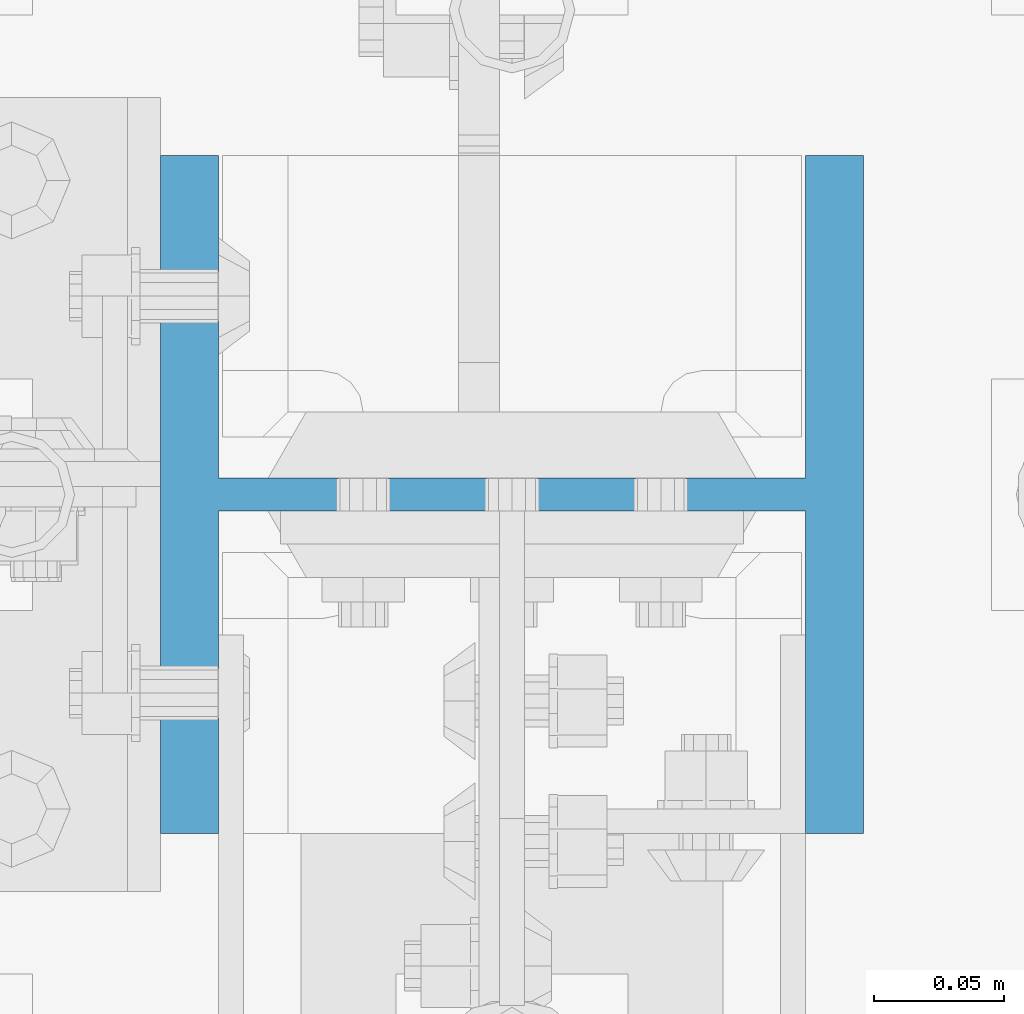
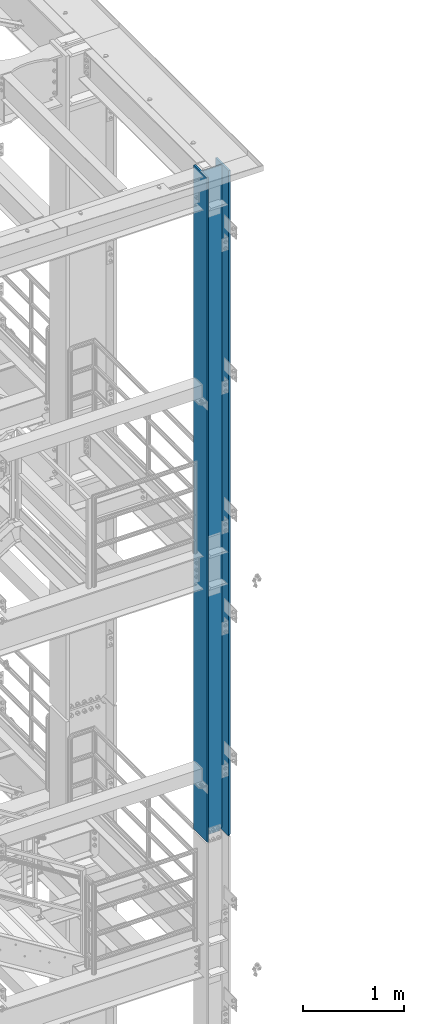
# One storey, part 652 of 1876: 1 column, 1 element without a shape of its own.
"""IFC2X3 building model written with IfcOpenShell, lengths in millimetres."""

from ifc_helpers import new_model, si_unit, frame, origin_with_axes, place, context, subcontext, project, spatial, faceted_brep, material, type_object, element, aggregate, save


model = new_model("IFC2X3")

# Units and contexts
model_context = context("Model", 3, precision=1e-05, world=origin_with_axes())
body_context = subcontext(model_context, "Body", "Model", "MODEL_VIEW")
ifc_project = project(units=[si_unit("LENGTHUNIT", "METRE", prefix="MILLI"), si_unit("AREAUNIT", "SQUARE_METRE"), si_unit("VOLUMEUNIT", "CUBIC_METRE"), si_unit("MASSUNIT", "GRAM", prefix="KILO"), si_unit("TIMEUNIT", "SECOND"), si_unit("PLANEANGLEUNIT", "RADIAN"), si_unit("SOLIDANGLEUNIT", "STERADIAN"), si_unit("THERMODYNAMICTEMPERATUREUNIT", "DEGREE_CELSIUS"), si_unit("LUMINOUSINTENSITYUNIT", "LUMEN")], contexts=[model_context])

# Site, building, storey
site_placement = place(None, origin_with_axes())
site = spatial("IfcSite", under=ifc_project, at=site_placement, CompositionType="ELEMENT")
building_placement = place(site_placement, origin_with_axes())
building = spatial("IfcBuilding", under=site, at=building_placement, Name="Undefined", CompositionType="ELEMENT")
storey_placement = place(building_placement, origin_with_axes())
storey = spatial("IfcBuildingStorey", under=building, at=storey_placement, Name="Undefined", CompositionType="ELEMENT", Elevation=0.0)

# Assembly, column
assembly_placement = place(storey_placement, origin_with_axes())
assembly = element("IfcElementAssembly", 1, at=assembly_placement, inside=storey, Name="COLUMN", AssemblyPlace="NOTDEFINED", PredefinedType="RIGID_FRAME")
ifc_material = material(Name="STEEL/A992")
column_type = type_object("IfcColumnType", Name="W10X77", PredefinedType="NOTDEFINED")
column_placement = place(assembly_placement, frame((7620.0, -7112.0, 14528.8), z_axis=(-1.0, 0.0, 0.0), x_axis=(0.0, 0.0, 1.0)))
column = element("IfcColumn", 2, at=column_placement, type_object=column_type, material=ifc_material, Name="COLUMN", ObjectType="W10X77", context=body_context, shape_type="Brep", body=[
    faceted_brep([(15.8749999999945, 6.35000000000036, 82.471111788822), (15.8749999999945, 6.35000000000036, -82.471111788822), (6.35000000000036, -3.17500029428084, -80.9625), (6.35000000000036, -3.17500029428084, 80.9625), (8026.39999999999, 130.175, -134.9375), (8026.39999999999, -130.175, -134.9375), (25.4000000342548, -130.175, -134.9375), (25.4000000342548, 130.175, -134.9375), (8026.39999999999, -130.175, -112.7125), (38.1000000342628, -130.175, -112.7125), (6.35000000000036, -130.175, -112.7125), (6.35000000000036, -130.175, -115.887499965744), (38.1000000342628, -6.35000000000036, -112.7125), (6.35000000000036, -6.35000000000036, -112.7125), (8026.39999999999, -6.35000000000036, -112.7125), (6.35000000000036, -130.175, 112.7125), (38.1000000342628, -130.175, 112.7125), (8026.39999999999, -130.175, 112.7125), (8026.39999999999, -130.175, 134.9375), (25.4000000342548, -130.175, 134.9375), (6.35000000000036, -130.175, 115.887499965744), (8026.39999999999, 130.175, 134.9375), (25.4000000342548, 130.175, 134.9375), (6.35000000000036, 130.175, 115.887499965744), (8026.39999999999, 130.175, 112.7125), (38.1000000342628, 130.175, 112.7125), (6.35000000000036, 130.175, 112.7125), (6.35000000000036, -6.35000000000036, 112.7125), (6.35000000000036, 6.35000000000036, 112.7125), (6.35000000000036, -3.17500029428084, 112.7125), (38.1000000342628, -6.35000000000036, 112.7125), (8026.39999999999, -6.35000000000036, 112.7125), (36.5460444266337, -6.35000000000036, 102.901210428595), (32.0362896056668, -6.35000000000036, 94.050318239714), (25.0121817945492, -6.35000000000036, 87.0262104285954), (16.1612896056668, -6.35000000000036, 82.5164556076289), (6.35000000000036, -6.35000000000036, 80.9625), (6.35000000000036, -6.35000000000036, -80.9625), (16.1612896056668, -6.35000000000036, -82.5164556076289), (25.0121817945492, -6.35000000000036, -87.0262104285954), (32.0362896056668, -6.35000000000036, -94.050318239714), (36.5460444266337, -6.35000000000036, -102.901210428595), (16.1612896056668, 6.35000000000036, -82.5164556076289), (25.0121817945492, 6.35000000000036, -87.0262104285954), (32.0362896056668, 6.35000000000036, -94.050318239714), (36.5460444266337, 6.35000000000036, -102.901210428595), (38.1000000342628, 6.35000000000036, -112.7125), (38.1000000342628, 130.175, -112.7125), (6.35000000000036, 130.175, -112.7125), (6.35000000000036, 6.35000000000036, -112.7125), (15.8749999999945, 6.35000000000036, -112.7125), (8026.39999999999, 6.35000000000036, -112.7125), (8026.39999999999, 130.175, -112.7125), (6.35000000000036, -3.17500029428084, -112.7125), (6.35000000000036, 130.175, -115.887499965744), (8026.39999999999, 6.35000000000036, 112.7125), (38.1000000342628, 6.35000000000036, 112.7125), (15.8749999999945, 6.35000000000036, 112.7125), (36.5460444266337, 6.35000000000036, 102.901210428595), (32.0362896056668, 6.35000000000036, 94.050318239714), (25.0121817945492, 6.35000000000036, 87.0262104285954), (16.1612896056668, 6.35000000000036, 82.5164556076289)], [[[0, 1, 2, 3]], [[4, 5, 6, 7]], [[5, 8, 9, 10, 11, 6]], [[12, 13, 10, 9, 8, 14]], [[15, 16, 17, 18, 19, 20]], [[18, 21, 22, 19]], [[19, 22, 23, 20]], [[21, 24, 25, 26, 23, 22]], [[27, 15, 20, 23, 26, 28, 29]], [[16, 15, 27, 30, 31, 17]], [[14, 31, 30, 32, 33, 34, 35, 36, 37, 38, 39, 40, 41, 12]], [[38, 42, 43, 39]], [[39, 43, 44, 40]], [[40, 44, 45, 41]], [[41, 45, 46, 12]], [[47, 48, 49, 50, 46, 51, 52]], [[12, 46, 50, 49, 53, 13]], [[49, 48, 54, 11, 10, 13, 53]], [[6, 11, 54, 7]], [[48, 47, 52, 4, 7, 54]], [[51, 55, 24, 21, 18, 17, 31, 14, 8, 5, 4, 52]], [[56, 57, 28, 26, 25, 24, 55]], [[27, 29, 28, 57, 56, 30]], [[30, 56, 58, 32]], [[32, 58, 59, 33]], [[33, 59, 60, 34]], [[34, 60, 61, 35]], [[36, 35, 61, 0, 3]], [[37, 36, 3, 2]], [[42, 38, 37, 2, 1]], [[61, 60, 59, 58, 56, 55, 51, 46, 45, 44, 43, 42, 1, 0]]]),
])
aggregate(assembly, [column])

save(model, "model.ifc")
